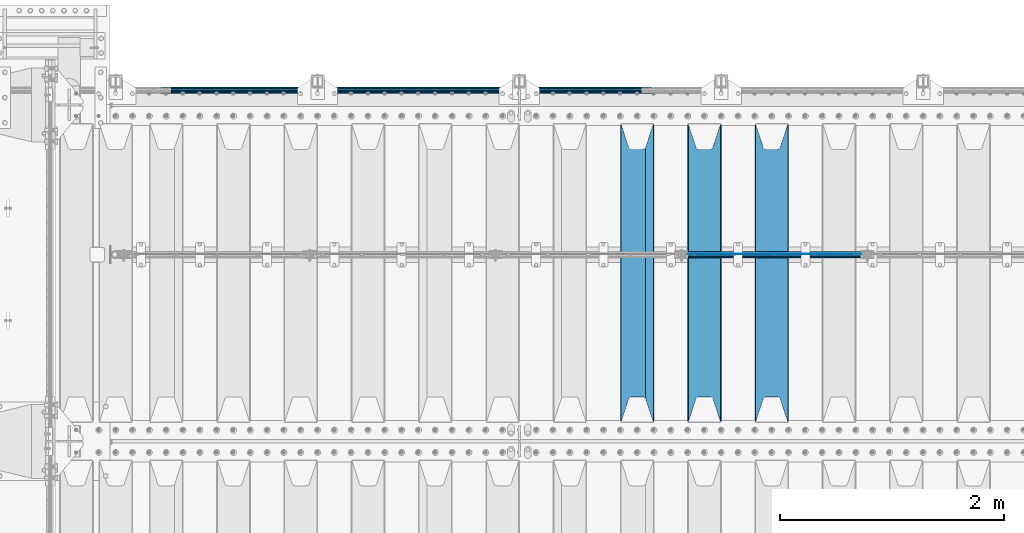
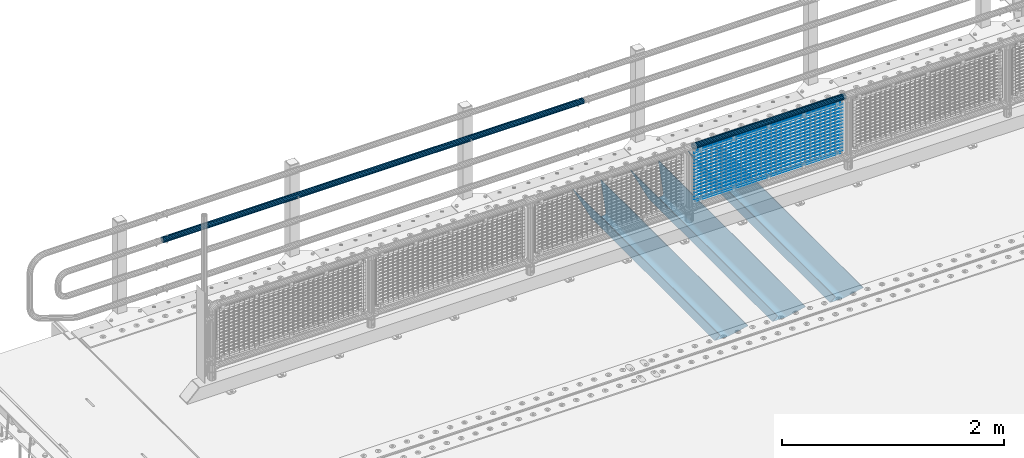
# One storey, part 112 of 219: 22 beams.
"""IFC2X3 building model written with IfcOpenShell, lengths in millimetres."""

from ifc_helpers import new_model, si_unit, frame, origin_with_axes, place, context, subcontext, project, spatial, faceted_brep, material, type_object, element, save


model = new_model("IFC2X3")

# Units and contexts
model_context = context("Model", 3, precision=1e-05, world=origin_with_axes())
body_context = subcontext(model_context, "Body", "Model", "MODEL_VIEW")
ifc_project = project(units=[si_unit("LENGTHUNIT", "METRE", prefix="MILLI"), si_unit("AREAUNIT", "SQUARE_METRE"), si_unit("VOLUMEUNIT", "CUBIC_METRE"), si_unit("MASSUNIT", "GRAM", prefix="KILO"), si_unit("TIMEUNIT", "SECOND"), si_unit("PLANEANGLEUNIT", "RADIAN"), si_unit("SOLIDANGLEUNIT", "STERADIAN"), si_unit("THERMODYNAMICTEMPERATUREUNIT", "DEGREE_CELSIUS"), si_unit("LUMINOUSINTENSITYUNIT", "LUMEN")], contexts=[model_context])

# Site, building, storey
site_placement = place(None, origin_with_axes())
site = spatial("IfcSite", under=ifc_project, at=site_placement, CompositionType="ELEMENT")
building_placement = place(site_placement, origin_with_axes())
building = spatial("IfcBuilding", under=site, at=building_placement, Name="Standard", CompositionType="ELEMENT")
storey_placement = place(building_placement, origin_with_axes())
storey = spatial("IfcBuildingStorey", under=building, at=storey_placement, Name="Undefined", CompositionType="ELEMENT", Elevation=0.0)

# Beams
ifc_material_1 = material(Name="STEEL/S355N")
beam_type_1 = type_object("IfcBeamType", PredefinedType="NOTDEFINED")
beam_1_placement = place(storey_placement, frame((6400.0, 30175.0, -115.0), z_axis=(0.0, 0.0, 1.0), x_axis=(0.0, 1.0, 0.0)))
element("IfcBeam", 1, at=beam_1_placement, inside=storey, type_object=beam_type_1, material=ifc_material_1, context=body_context, shape_type="Brep", body=[
    faceted_brep([(0.0, 150.0, 115.0), (0.0, 143.690000000001, 115.0), (2650.00000000297, 143.690000000001, 115.0), (2650.00000000297, 150.0, 115.0), (2650.00000000297, 142.0595652184, 110.000000003094), (2650.00000000297, 148.3695652184, 110.000000003094), (2441.90079219209, -80.110360073113, -98.0992078077845), (2437.7588105432, -77.5672621345566, -102.241189456673), (2434.06523489747, -74.4080125315541, -105.934765102404), (2430.9108609509, -70.7102721255742, -109.089139048974), (2428.37322971128, -66.5649389910068, -111.626770288588), (2426.51472138055, -62.0739139532889, -113.485278619323), (2425.38102192092, -57.3475956567672, -114.618978078955), (2424.99999999988, -52.5021667386536, -115.0), (2424.99999999988, 52.5021667386536, -115.0), (2425.38102192092, 57.3475956567672, -114.618978078955), (2426.51472138055, 62.0739139532889, -113.485278619323), (2428.37322971128, 66.5649389910068, -111.626770288588), (2430.9108609509, 70.7102721255742, -109.089139048974), (2434.06523489747, 74.4080125315541, -105.934765102404), (2437.7588105432, 77.5672621345566, -102.241189456673), (2441.90079219209, 80.110360073113, -98.0992078077846), (2446.38936140512, 81.9747917625791, -93.6106385947584), (2448.2494850041, 76.2713538057269, -91.7505149957729), (2444.62967112263, 74.7677798626082, -95.3703288772456), (2441.28936334127, 72.7168944282894, -98.710636658607), (2438.31067330439, 70.1691124903828, -101.689326695487), (2435.76682334748, 67.1870637758839, -104.233176652398), (2433.72034654134, 63.8440531834913, -106.279653458539), (2432.22154950042, 60.2222587982342, -107.778450499454), (2431.30727574265, 56.4107117849107, -108.692724257221), (2430.99999999987, 52.5031078186894, -109.0), (2430.99999999987, -52.5031078186894, -109.0), (2431.30727574265, -56.4107117849107, -108.692724257221), (2432.22154950042, -60.2222587982342, -107.778450499454), (2433.72034654134, -63.8440531834913, -106.279653458539), (2435.76682334748, -67.1870637758839, -104.233176652398), (2438.31067330439, -70.1691124903828, -101.689326695487), (2441.28936334127, -72.7168944282894, -98.7106366586071), (2444.62967112263, -74.7677798626082, -95.3703288772457), (2448.2494850041, -76.2713538057269, -91.7505149957729), (2650.00000000297, -142.0595652184, 110.000000003094), (2650.00000000297, -148.3695652184, 110.000000003094), (2446.38936140512, -81.9747917625791, -93.6106385947584), (2650.00000000297, -143.690000000001, 115.0), (2650.00000000297, -150.0, 115.0), (0.0, -143.690000000001, 115.0), (0.0, -150.0, 115.0), (0.0, -148.369565218261, 110.000000002667), (203.610638597427, -81.9747917625791, -93.6106385947584), (208.09920781045, -80.110360073113, -98.0992078077845), (212.241189459342, -77.5672621345566, -102.241189456673), (215.93476510507, -74.4080125315541, -105.934765102404), (219.089139051641, -70.7102721255742, -109.089139048974), (221.626770291256, -66.5649389910068, -111.626770288588), (223.485278621989, -62.0739139532889, -113.485278619323), (224.618978081624, -57.3475956567672, -114.618978078955), (225.000000002663, -52.5021667386536, -115.0), (225.000000002663, 52.5021667386536, -115.0), (224.618978081624, 57.3475956567672, -114.618978078955), (223.485278621989, 62.0739139532889, -113.485278619323), (221.626770291256, 66.5649389910068, -111.626770288588), (219.089139051641, 70.7102721255742, -109.089139048974), (215.93476510507, 74.4080125315541, -105.934765102404), (212.241189459342, 77.5672621345566, -102.241189456673), (208.09920781045, 80.110360073113, -98.0992078077846), (203.610638597427, 81.9747917625791, -93.6106385947584), (0.0, 148.369565218261, 110.000000002667), (0.0, 142.059565218262, 110.000000002667), (201.750514998439, 76.2713538057269, -91.7505149957729), (205.370328879915, 74.7677798626082, -95.3703288772456), (208.710636661275, 72.7168944282894, -98.710636658607), (211.689326698157, 70.1691124903828, -101.689326695487), (214.233176655063, 67.1870637758839, -104.233176652398), (216.279653461206, 63.8440531834913, -106.279653458539), (217.778450502123, 60.2222587982342, -107.778450499454), (218.69272425989, 56.4107117849107, -108.692724257221), (219.00000000267, 52.5031078186894, -109.0), (219.00000000267, -52.5031078186894, -109.0), (218.69272425989, -56.4107117849107, -108.692724257221), (217.778450502123, -60.2222587982342, -107.778450499454), (216.279653461206, -63.8440531834913, -106.279653458539), (214.233176655063, -67.1870637758839, -104.233176652398), (211.689326698157, -70.1691124903828, -101.689326695487), (208.710636661275, -72.7168944282894, -98.7106366586071), (205.370328879915, -74.7677798626082, -95.3703288772457), (201.750514998439, -76.2713538057269, -91.7505149957729), (0.0, -142.059565218262, 110.000000002667)], [[[0, 1, 2, 3]], [[3, 2, 4, 5]], [[6, 7, 8, 9, 10, 11, 12, 13, 14, 15, 16, 17, 18, 19, 20, 21, 22, 5, 4, 23, 24, 25, 26, 27, 28, 29, 30, 31, 32, 33, 34, 35, 36, 37, 38, 39, 40, 41, 42, 43]], [[44, 45, 42, 41]], [[46, 47, 45, 44]], [[43, 42, 45, 47, 48, 49]], [[6, 43, 49, 50]], [[7, 6, 50, 51]], [[8, 7, 51, 52]], [[9, 8, 52, 53]], [[10, 9, 53, 54]], [[11, 10, 54, 55]], [[12, 11, 55, 56]], [[13, 12, 56, 57]], [[14, 13, 57, 58]], [[15, 14, 58, 59]], [[16, 15, 59, 60]], [[17, 16, 60, 61]], [[18, 17, 61, 62]], [[19, 18, 62, 63]], [[20, 19, 63, 64]], [[21, 20, 64, 65]], [[22, 21, 65, 66]], [[0, 3, 5, 22, 66, 67]], [[1, 0, 67, 68]], [[23, 4, 2, 1, 68, 69]], [[24, 23, 69, 70]], [[25, 24, 70, 71]], [[26, 25, 71, 72]], [[27, 26, 72, 73]], [[28, 27, 73, 74]], [[29, 28, 74, 75]], [[30, 29, 75, 76]], [[31, 30, 76, 77]], [[32, 31, 77, 78]], [[33, 32, 78, 79]], [[34, 33, 79, 80]], [[35, 34, 80, 81]], [[36, 35, 81, 82]], [[37, 36, 82, 83]], [[38, 37, 83, 84]], [[39, 38, 84, 85]], [[40, 39, 85, 86]], [[46, 44, 41, 40, 86, 87]], [[47, 46, 87, 48]], [[86, 85, 84, 83, 82, 81, 80, 79, 78, 77, 76, 75, 74, 73, 72, 71, 70, 69, 68, 67, 66, 65, 64, 63, 62, 61, 60, 59, 58, 57, 56, 55, 54, 53, 52, 51, 50, 49, 48, 87]]]),
])
beam_2_placement = place(storey_placement, frame((5800.0, 30175.0, -115.0), z_axis=(0.0, 0.0, 1.0), x_axis=(0.0, 1.0, 0.0)))
element("IfcBeam", 2, at=beam_2_placement, inside=storey, type_object=beam_type_1, material=ifc_material_1, context=body_context, shape_type="Brep", body=[
    faceted_brep([(0.0, 150.0, 115.0), (0.0, 143.690000000001, 115.0), (2650.00000000297, 143.690000000001, 115.0), (2650.00000000297, 150.0, 115.0), (2650.00000000297, 142.0595652184, 110.000000003094), (2650.00000000297, 148.3695652184, 110.000000003094), (2441.90079219209, -80.110360073113, -98.0992078077845), (2437.7588105432, -77.5672621345566, -102.241189456673), (2434.06523489747, -74.4080125315541, -105.934765102404), (2430.9108609509, -70.7102721255742, -109.089139048974), (2428.37322971128, -66.5649389910068, -111.626770288588), (2426.51472138055, -62.0739139532889, -113.485278619323), (2425.38102192092, -57.3475956567672, -114.618978078955), (2424.99999999988, -52.5021667386536, -115.0), (2424.99999999988, 52.5021667386536, -115.0), (2425.38102192092, 57.3475956567672, -114.618978078955), (2426.51472138055, 62.0739139532889, -113.485278619323), (2428.37322971128, 66.5649389910068, -111.626770288588), (2430.9108609509, 70.7102721255742, -109.089139048974), (2434.06523489747, 74.4080125315541, -105.934765102404), (2437.7588105432, 77.5672621345566, -102.241189456673), (2441.90079219209, 80.110360073113, -98.0992078077846), (2446.38936140512, 81.9747917625791, -93.6106385947584), (2448.2494850041, 76.2713538057269, -91.7505149957729), (2444.62967112263, 74.7677798626082, -95.3703288772456), (2441.28936334127, 72.7168944282894, -98.710636658607), (2438.31067330439, 70.1691124903828, -101.689326695487), (2435.76682334748, 67.1870637758839, -104.233176652398), (2433.72034654134, 63.8440531834913, -106.279653458539), (2432.22154950042, 60.2222587982342, -107.778450499454), (2431.30727574265, 56.4107117849107, -108.692724257221), (2430.99999999987, 52.5031078186894, -109.0), (2430.99999999987, -52.5031078186894, -109.0), (2431.30727574265, -56.4107117849107, -108.692724257221), (2432.22154950042, -60.2222587982342, -107.778450499454), (2433.72034654134, -63.8440531834913, -106.279653458539), (2435.76682334748, -67.1870637758839, -104.233176652398), (2438.31067330439, -70.1691124903828, -101.689326695487), (2441.28936334127, -72.7168944282894, -98.7106366586071), (2444.62967112263, -74.7677798626082, -95.3703288772457), (2448.2494850041, -76.2713538057269, -91.7505149957729), (2650.00000000297, -142.0595652184, 110.000000003094), (2650.00000000297, -148.3695652184, 110.000000003094), (2446.38936140512, -81.9747917625791, -93.6106385947584), (2650.00000000297, -143.690000000001, 115.0), (2650.00000000297, -150.0, 115.0), (0.0, -143.690000000001, 115.0), (0.0, -150.0, 115.0), (0.0, -148.369565218261, 110.000000002667), (203.610638597427, -81.9747917625791, -93.6106385947584), (208.09920781045, -80.110360073113, -98.0992078077845), (212.241189459342, -77.5672621345566, -102.241189456673), (215.93476510507, -74.4080125315541, -105.934765102404), (219.089139051641, -70.7102721255742, -109.089139048974), (221.626770291256, -66.5649389910068, -111.626770288588), (223.485278621989, -62.0739139532889, -113.485278619323), (224.618978081624, -57.3475956567672, -114.618978078955), (225.000000002663, -52.5021667386536, -115.0), (225.000000002663, 52.5021667386536, -115.0), (224.618978081624, 57.3475956567672, -114.618978078955), (223.485278621989, 62.0739139532889, -113.485278619323), (221.626770291256, 66.5649389910068, -111.626770288588), (219.089139051641, 70.7102721255742, -109.089139048974), (215.93476510507, 74.4080125315541, -105.934765102404), (212.241189459342, 77.5672621345566, -102.241189456673), (208.09920781045, 80.110360073113, -98.0992078077846), (203.610638597427, 81.9747917625791, -93.6106385947584), (0.0, 148.369565218261, 110.000000002667), (0.0, 142.059565218262, 110.000000002667), (201.750514998439, 76.2713538057269, -91.7505149957729), (205.370328879915, 74.7677798626082, -95.3703288772456), (208.710636661275, 72.7168944282894, -98.710636658607), (211.689326698157, 70.1691124903828, -101.689326695487), (214.233176655063, 67.1870637758839, -104.233176652398), (216.279653461206, 63.8440531834913, -106.279653458539), (217.778450502123, 60.2222587982342, -107.778450499454), (218.69272425989, 56.4107117849107, -108.692724257221), (219.00000000267, 52.5031078186894, -109.0), (219.00000000267, -52.5031078186894, -109.0), (218.69272425989, -56.4107117849107, -108.692724257221), (217.778450502123, -60.2222587982342, -107.778450499454), (216.279653461206, -63.8440531834913, -106.279653458539), (214.233176655063, -67.1870637758839, -104.233176652398), (211.689326698157, -70.1691124903828, -101.689326695487), (208.710636661275, -72.7168944282894, -98.7106366586071), (205.370328879915, -74.7677798626082, -95.3703288772457), (201.750514998439, -76.2713538057269, -91.7505149957729), (0.0, -142.059565218262, 110.000000002667)], [[[0, 1, 2, 3]], [[3, 2, 4, 5]], [[6, 7, 8, 9, 10, 11, 12, 13, 14, 15, 16, 17, 18, 19, 20, 21, 22, 5, 4, 23, 24, 25, 26, 27, 28, 29, 30, 31, 32, 33, 34, 35, 36, 37, 38, 39, 40, 41, 42, 43]], [[44, 45, 42, 41]], [[46, 47, 45, 44]], [[43, 42, 45, 47, 48, 49]], [[6, 43, 49, 50]], [[7, 6, 50, 51]], [[8, 7, 51, 52]], [[9, 8, 52, 53]], [[10, 9, 53, 54]], [[11, 10, 54, 55]], [[12, 11, 55, 56]], [[13, 12, 56, 57]], [[14, 13, 57, 58]], [[15, 14, 58, 59]], [[16, 15, 59, 60]], [[17, 16, 60, 61]], [[18, 17, 61, 62]], [[19, 18, 62, 63]], [[20, 19, 63, 64]], [[21, 20, 64, 65]], [[22, 21, 65, 66]], [[0, 3, 5, 22, 66, 67]], [[1, 0, 67, 68]], [[23, 4, 2, 1, 68, 69]], [[24, 23, 69, 70]], [[25, 24, 70, 71]], [[26, 25, 71, 72]], [[27, 26, 72, 73]], [[28, 27, 73, 74]], [[29, 28, 74, 75]], [[30, 29, 75, 76]], [[31, 30, 76, 77]], [[32, 31, 77, 78]], [[33, 32, 78, 79]], [[34, 33, 79, 80]], [[35, 34, 80, 81]], [[36, 35, 81, 82]], [[37, 36, 82, 83]], [[38, 37, 83, 84]], [[39, 38, 84, 85]], [[40, 39, 85, 86]], [[46, 44, 41, 40, 86, 87]], [[47, 46, 87, 48]], [[86, 85, 84, 83, 82, 81, 80, 79, 78, 77, 76, 75, 74, 73, 72, 71, 70, 69, 68, 67, 66, 65, 64, 63, 62, 61, 60, 59, 58, 57, 56, 55, 54, 53, 52, 51, 50, 49, 48, 87]]]),
])
beam_3_placement = place(storey_placement, frame((5200.0, 30175.0, -115.0), z_axis=(0.0, 0.0, 1.0), x_axis=(0.0, 1.0, 0.0)))
element("IfcBeam", 3, at=beam_3_placement, inside=storey, type_object=beam_type_1, material=ifc_material_1, context=body_context, shape_type="Brep", body=[
    faceted_brep([(0.0, 150.0, 115.0), (0.0, 143.690000000001, 115.0), (2650.00000000297, 143.690000000001, 115.0), (2650.00000000297, 150.0, 115.0), (2650.00000000297, 142.0595652184, 110.000000003094), (2650.00000000297, 148.3695652184, 110.000000003094), (2441.90079219209, -80.110360073113, -98.0992078077845), (2437.7588105432, -77.5672621345566, -102.241189456673), (2434.06523489747, -74.4080125315541, -105.934765102404), (2430.9108609509, -70.7102721255742, -109.089139048974), (2428.37322971128, -66.5649389910068, -111.626770288588), (2426.51472138055, -62.0739139532889, -113.485278619323), (2425.38102192092, -57.3475956567672, -114.618978078955), (2424.99999999988, -52.5021667386536, -115.0), (2424.99999999988, 52.5021667386536, -115.0), (2425.38102192092, 57.3475956567672, -114.618978078955), (2426.51472138055, 62.0739139532889, -113.485278619323), (2428.37322971128, 66.5649389910068, -111.626770288588), (2430.9108609509, 70.7102721255742, -109.089139048974), (2434.06523489747, 74.4080125315541, -105.934765102404), (2437.7588105432, 77.5672621345566, -102.241189456673), (2441.90079219209, 80.110360073113, -98.0992078077846), (2446.38936140512, 81.9747917625791, -93.6106385947584), (2448.2494850041, 76.2713538057269, -91.7505149957729), (2444.62967112263, 74.7677798626082, -95.3703288772456), (2441.28936334127, 72.7168944282894, -98.710636658607), (2438.31067330439, 70.1691124903828, -101.689326695487), (2435.76682334748, 67.1870637758839, -104.233176652398), (2433.72034654134, 63.8440531834913, -106.279653458539), (2432.22154950042, 60.2222587982342, -107.778450499454), (2431.30727574265, 56.4107117849107, -108.692724257221), (2430.99999999987, 52.5031078186894, -109.0), (2430.99999999987, -52.5031078186894, -109.0), (2431.30727574265, -56.4107117849107, -108.692724257221), (2432.22154950042, -60.2222587982342, -107.778450499454), (2433.72034654134, -63.8440531834913, -106.279653458539), (2435.76682334748, -67.1870637758839, -104.233176652398), (2438.31067330439, -70.1691124903828, -101.689326695487), (2441.28936334127, -72.7168944282894, -98.7106366586071), (2444.62967112263, -74.7677798626082, -95.3703288772457), (2448.2494850041, -76.2713538057269, -91.7505149957729), (2650.00000000297, -142.0595652184, 110.000000003094), (2650.00000000297, -148.3695652184, 110.000000003094), (2446.38936140512, -81.9747917625791, -93.6106385947584), (2650.00000000297, -143.690000000001, 115.0), (2650.00000000297, -150.0, 115.0), (0.0, -143.690000000001, 115.0), (0.0, -150.0, 115.0), (0.0, -148.369565218261, 110.000000002667), (203.610638597427, -81.9747917625791, -93.6106385947584), (208.09920781045, -80.110360073113, -98.0992078077845), (212.241189459342, -77.5672621345566, -102.241189456673), (215.93476510507, -74.4080125315541, -105.934765102404), (219.089139051641, -70.7102721255742, -109.089139048974), (221.626770291256, -66.5649389910068, -111.626770288588), (223.485278621989, -62.0739139532889, -113.485278619323), (224.618978081624, -57.3475956567672, -114.618978078955), (225.000000002663, -52.5021667386536, -115.0), (225.000000002663, 52.5021667386536, -115.0), (224.618978081624, 57.3475956567672, -114.618978078955), (223.485278621989, 62.0739139532889, -113.485278619323), (221.626770291256, 66.5649389910068, -111.626770288588), (219.089139051641, 70.7102721255742, -109.089139048974), (215.93476510507, 74.4080125315541, -105.934765102404), (212.241189459342, 77.5672621345566, -102.241189456673), (208.09920781045, 80.110360073113, -98.0992078077846), (203.610638597427, 81.9747917625791, -93.6106385947584), (0.0, 148.369565218261, 110.000000002667), (0.0, 142.059565218262, 110.000000002667), (201.750514998439, 76.2713538057269, -91.7505149957729), (205.370328879915, 74.7677798626082, -95.3703288772456), (208.710636661275, 72.7168944282894, -98.710636658607), (211.689326698157, 70.1691124903828, -101.689326695487), (214.233176655063, 67.1870637758839, -104.233176652398), (216.279653461206, 63.8440531834913, -106.279653458539), (217.778450502123, 60.2222587982342, -107.778450499454), (218.69272425989, 56.4107117849107, -108.692724257221), (219.00000000267, 52.5031078186894, -109.0), (219.00000000267, -52.5031078186894, -109.0), (218.69272425989, -56.4107117849107, -108.692724257221), (217.778450502123, -60.2222587982342, -107.778450499454), (216.279653461206, -63.8440531834913, -106.279653458539), (214.233176655063, -67.1870637758839, -104.233176652398), (211.689326698157, -70.1691124903828, -101.689326695487), (208.710636661275, -72.7168944282894, -98.7106366586071), (205.370328879915, -74.7677798626082, -95.3703288772457), (201.750514998439, -76.2713538057269, -91.7505149957729), (0.0, -142.059565218262, 110.000000002667)], [[[0, 1, 2, 3]], [[3, 2, 4, 5]], [[6, 7, 8, 9, 10, 11, 12, 13, 14, 15, 16, 17, 18, 19, 20, 21, 22, 5, 4, 23, 24, 25, 26, 27, 28, 29, 30, 31, 32, 33, 34, 35, 36, 37, 38, 39, 40, 41, 42, 43]], [[44, 45, 42, 41]], [[46, 47, 45, 44]], [[43, 42, 45, 47, 48, 49]], [[6, 43, 49, 50]], [[7, 6, 50, 51]], [[8, 7, 51, 52]], [[9, 8, 52, 53]], [[10, 9, 53, 54]], [[11, 10, 54, 55]], [[12, 11, 55, 56]], [[13, 12, 56, 57]], [[14, 13, 57, 58]], [[15, 14, 58, 59]], [[16, 15, 59, 60]], [[17, 16, 60, 61]], [[18, 17, 61, 62]], [[19, 18, 62, 63]], [[20, 19, 63, 64]], [[21, 20, 64, 65]], [[22, 21, 65, 66]], [[0, 3, 5, 22, 66, 67]], [[1, 0, 67, 68]], [[23, 4, 2, 1, 68, 69]], [[24, 23, 69, 70]], [[25, 24, 70, 71]], [[26, 25, 71, 72]], [[27, 26, 72, 73]], [[28, 27, 73, 74]], [[29, 28, 74, 75]], [[30, 29, 75, 76]], [[31, 30, 76, 77]], [[32, 31, 77, 78]], [[33, 32, 78, 79]], [[34, 33, 79, 80]], [[35, 34, 80, 81]], [[36, 35, 81, 82]], [[37, 36, 82, 83]], [[38, 37, 83, 84]], [[39, 38, 84, 85]], [[40, 39, 85, 86]], [[46, 44, 41, 40, 86, 87]], [[47, 46, 87, 48]], [[86, 85, 84, 83, 82, 81, 80, 79, 78, 77, 76, 75, 74, 73, 72, 71, 70, 69, 68, 67, 66, 65, 64, 63, 62, 61, 60, 59, 58, 57, 56, 55, 54, 53, 52, 51, 50, 49, 48, 87]]]),
])
ifc_material_2 = material(Name="Misc_Undefined")
beam_type_2 = type_object("IfcBeamType", Name="D3", PredefinedType="NOTDEFINED")
for number, where, z_axis, x_axis in (
    (4, (5650.0, 31670.5, 851.597), (0.0, 0.0, 1.0), (1.0, 0.0, 0.0)),
    (5, (5650.0, 31670.5, 669.452), (0.0, 0.0, 1.0), (1.0, 0.0, 0.0)),
    (6, (5650.0, 31670.5, 523.736), (0.0, 0.0, 1.0), (1.0, 0.0, 0.0)),
    (7, (5650.0, 31670.5, 487.307), (0.0, 0.0, 1.0), (1.0, 0.0, 0.0)),
    (8, (5650.0, 31670.5, 705.881), (0.0, 0.0, 1.0), (1.0, 0.0, 0.0)),
    (9, (5650.0, 31670.5, 596.594000000001), (0.0, 0.0, 1.0), (1.0, 0.0, 0.0)),
    (10, (5650.0, 31670.5, 450.878), (0.0, 0.0, 1.0), (1.0, 0.0, 0.0)),
    (11, (5650.0, 31670.5, 815.168), (0.0, 0.0, 1.0), (1.0, 0.0, 0.0)),
    (12, (5650.0, 31670.5, 888.026), (0.0, 0.0, 1.0), (1.0, 0.0, 0.0)),
    (13, (5650.0, 31670.5, 778.739), (0.0, 0.0, 1.0), (1.0, 0.0, 0.0)),
    (14, (5650.0, 31670.5, 742.31), (0.0, 0.0, 1.0), (1.0, 0.0, 0.0)),
    (15, (5650.0, 31670.5, 633.023), (0.0, 0.0, 1.0), (1.0, 0.0, 0.0)),
    (16, (5650.0, 31670.5, 560.165), (0.0, 0.0, 1.0), (1.0, 0.0, 0.0)),
    (17, (5650.0, 31670.5, 414.449), (0.0, 0.0, 1.0), (1.0, 0.0, 0.0)),
):
    element("IfcBeam", number, at=place(storey_placement, frame(where, z_axis=z_axis, x_axis=x_axis)), inside=storey, type_object=beam_type_2, material=ifc_material_2, ObjectType="D3", context=body_context, shape_type="Brep", body=[
        faceted_brep([(0.0, -1.5, -5.6843418860808e-14), (0.0, -0.75, -1.29903810567669), (1548.0, -0.75, -1.29903810567669), (1548.0, -1.5, 0.0), (0.0, 0.75, -1.29903810567669), (1548.0, 0.75, -1.29903810567669), (0.0, 1.5, -5.6843418860808e-14), (1548.0, 1.5, 0.0), (0.0, 0.75, 1.29903810567669), (1548.0, 0.75, 1.29903810567669), (0.0, -0.75, 1.29903810567669), (1548.0, -0.75, 1.29903810567669)], [[[0, 1, 2, 3]], [[1, 4, 5, 2]], [[4, 6, 7, 5]], [[6, 8, 9, 7]], [[8, 10, 11, 9]], [[10, 0, 3, 11]], [[5, 7, 9, 11, 3, 2]], [[10, 8, 6, 4, 1, 0]]]),
    ])
beam_4_placement = place(storey_placement, frame((5675.0, 31670.5, 353.02), z_axis=(0.0, 0.0, 1.0), x_axis=(1.0, 0.0, 0.0)))
element("IfcBeam", 18, at=beam_4_placement, inside=storey, type_object=beam_type_2, material=ifc_material_2, ObjectType="D3", context=body_context, shape_type="Brep", body=[
    faceted_brep([(0.0, -1.5, -5.6843418860808e-14), (0.0, -0.75, -1.29903810567669), (1498.0, -0.75, -1.29903810567669), (1498.0, -1.5, 0.0), (0.0, 0.75, -1.29903810567669), (1498.0, 0.75, -1.29903810567663), (0.0, 1.5, -5.6843418860808e-14), (1498.0, 1.5, 0.0), (0.0, 0.75, 1.29903810567669), (1498.0, 0.75, 1.29903810567669), (0.0, -0.75, 1.29903810567669), (1498.0, -0.75, 1.29903810567669)], [[[0, 1, 2, 3]], [[1, 4, 5, 2]], [[4, 6, 7, 5]], [[6, 8, 9, 7]], [[8, 10, 11, 9]], [[10, 0, 3, 11]], [[5, 7, 9, 11, 3, 2]], [[10, 8, 6, 4, 1, 0]]]),
])
beam_5_placement = place(storey_placement, frame((5650.0, 31670.5, 378.02), z_axis=(0.0, 0.0, 1.0), x_axis=(1.0, 0.0, 0.0)))
element("IfcBeam", 19, at=beam_5_placement, inside=storey, type_object=beam_type_2, material=ifc_material_2, ObjectType="D3", context=body_context, shape_type="Brep", body=[
    faceted_brep([(0.0, -1.5, -5.6843418860808e-14), (0.0, -0.75, -1.29903810567669), (1548.0, -0.75, -1.29903810567669), (1548.0, -1.5, 0.0), (0.0, 0.75, -1.29903810567669), (1548.0, 0.75, -1.29903810567669), (0.0, 1.5, -5.6843418860808e-14), (1548.0, 1.5, 0.0), (0.0, 0.75, 1.29903810567669), (1548.0, 0.75, 1.29903810567669), (0.0, -0.75, 1.29903810567669), (1548.0, -0.75, 1.29903810567669)], [[[0, 1, 2, 3]], [[1, 4, 5, 2]], [[4, 6, 7, 5]], [[6, 8, 9, 7]], [[8, 10, 11, 9]], [[10, 0, 3, 11]], [[5, 7, 9, 11, 3, 2]], [[10, 8, 6, 4, 1, 0]]]),
])
beam_6_placement = place(storey_placement, frame((5675.0, 31670.5, 913.02), z_axis=(0.0, 0.0, 1.0), x_axis=(1.0, 0.0, 0.0)))
element("IfcBeam", 20, at=beam_6_placement, inside=storey, type_object=beam_type_2, material=ifc_material_2, ObjectType="D3", context=body_context, shape_type="Brep", body=[
    faceted_brep([(0.0, -1.5, -5.6843418860808e-14), (0.0, -0.75, -1.29903810567669), (1498.0, -0.75, -1.29903810567669), (1498.0, -1.5, 0.0), (0.0, 0.75, -1.29903810567669), (1498.0, 0.75, -1.29903810567663), (0.0, 1.5, -5.6843418860808e-14), (1498.0, 1.5, 0.0), (0.0, 0.75, 1.29903810567669), (1498.0, 0.75, 1.29903810567669), (0.0, -0.75, 1.29903810567669), (1498.0, -0.75, 1.29903810567669)], [[[0, 1, 2, 3]], [[1, 4, 5, 2]], [[4, 6, 7, 5]], [[6, 8, 9, 7]], [[8, 10, 11, 9]], [[10, 0, 3, 11]], [[5, 7, 9, 11, 3, 2]], [[10, 8, 6, 4, 1, 0]]]),
])
ifc_material_3 = material()
beam_type_3 = type_object("IfcBeamType", PredefinedType="NOTDEFINED")
beam_7_placement = place(storey_placement, frame((5629.85, 31664.5, 969.85), z_axis=(0.0, 0.0, 1.0), x_axis=(1.0, 0.0, 0.0)))
element("IfcBeam", 21, at=beam_7_placement, inside=storey, type_object=beam_type_3, material=ifc_material_3, context=body_context, shape_type="Brep", body=[
    faceted_brep([(0.0, -25.3499999999985, 0.0), (0.0, -23.4203461491597, 9.70102501045585), (1588.0, -23.4203461491597, 9.70102501045506), (1588.0, -25.3499999999985, 0.0), (0.0, -17.9251569030785, 17.9251569030785), (1588.0, -17.9251569030785, 17.925156903079), (0.0, -9.70102501045403, 23.4203461491616), (1588.0, -9.70102501045403, 23.4203461491611), (0.0, 0.0, 25.3500000000004), (1588.0, 0.0, 25.35), (0.0, 9.70102501045403, 23.4203461491616), (1588.0, 9.70102501045403, 23.4203461491611), (0.0, 17.9251569030785, 17.9251569030785), (1588.0, 17.9251569030785, 17.925156903079), (0.0, 23.4203461491597, 9.70102501045585), (1588.0, 23.4203461491597, 9.70102501045506), (0.0, 25.3499999999985, 0.0), (1588.0, 25.3499999999985, 0.0), (0.0, 23.4203461491597, -9.70102501045585), (1588.0, 23.4203461491597, -9.70102501045506), (0.0, 17.9251569030785, -17.9251569030785), (1588.0, 17.9251569030785, -17.925156903079), (0.0, 9.70102501045403, -23.4203461491616), (1588.0, 9.70102501045403, -23.4203461491611), (0.0, 0.0, -25.3500000000004), (1588.0, 0.0, -25.35), (0.0, -9.70102501045403, -23.4203461491616), (1588.0, -9.70102501045403, -23.4203461491611), (0.0, -17.9251569030785, -17.9251569030785), (1588.0, -17.9251569030785, -17.925156903079), (0.0, -23.4203461491597, -9.70102501045585), (1588.0, -23.4203461491597, -9.70102501045506), (0.0, -30.1500000000015, 0.0), (0.0, -27.8549679052157, -11.5379054858076), (1588.0, -27.8549679052157, -11.5379054858075), (1588.0, -30.1500000000015, 0.0), (0.0, -21.3192694527752, -21.3192694527752), (1588.0, -21.3192694527752, -21.3192694527744), (0.0, -11.5379054858058, -27.8549679052157), (1588.0, -11.5379054858058, -27.8549679052153), (0.0, 0.0, -30.1499999999996), (1588.0, 0.0, -30.15), (0.0, 11.5379054858058, -27.8549679052157), (1588.0, 11.5379054858058, -27.8549679052153), (0.0, 21.3192694527752, -21.3192694527752), (1588.0, 21.3192694527752, -21.3192694527744), (0.0, 27.8549679052157, -11.5379054858076), (1588.0, 27.8549679052157, -11.5379054858074), (0.0, 30.1500000000015, 0.0), (1588.0, 30.1500000000015, 0.0), (0.0, 27.8549679052157, 11.5379054858076), (1588.0, 27.8549679052157, 11.5379054858074), (0.0, 21.3192694527752, 21.3192694527752), (1588.0, 21.3192694527752, 21.3192694527744), (0.0, 11.5379054858058, 27.8549679052157), (1588.0, 11.5379054858058, 27.8549679052153), (0.0, 0.0, 30.1499999999996), (1588.0, 0.0, 30.15), (0.0, -11.5379054858058, 27.8549679052157), (1588.0, -11.5379054858058, 27.8549679052153), (0.0, -21.3192694527752, 21.3192694527752), (1588.0, -21.3192694527752, 21.3192694527744), (0.0, -27.8549679052157, 11.5379054858076), (1588.0, -27.8549679052157, 11.5379054858074)], [[[0, 1, 2, 3]], [[1, 4, 5, 2]], [[4, 6, 7, 5]], [[6, 8, 9, 7]], [[8, 10, 11, 9]], [[10, 12, 13, 11]], [[12, 14, 15, 13]], [[14, 16, 17, 15]], [[16, 18, 19, 17]], [[18, 20, 21, 19]], [[20, 22, 23, 21]], [[22, 24, 25, 23]], [[24, 26, 27, 25]], [[26, 28, 29, 27]], [[28, 30, 31, 29]], [[30, 0, 3, 31]], [[32, 33, 34, 35]], [[33, 36, 37, 34]], [[36, 38, 39, 37]], [[38, 40, 41, 39]], [[40, 42, 43, 41]], [[42, 44, 45, 43]], [[44, 46, 47, 45]], [[46, 48, 49, 47]], [[48, 50, 51, 49]], [[50, 52, 53, 51]], [[52, 54, 55, 53]], [[54, 56, 57, 55]], [[56, 58, 59, 57]], [[58, 60, 61, 59]], [[60, 62, 63, 61]], [[62, 32, 35, 63]], [[37, 39, 41, 43, 45, 47, 49, 51, 53, 55, 57, 59, 61, 63, 35, 34], [5, 7, 9, 11, 13, 15, 17, 19, 21, 23, 25, 27, 29, 31, 3, 2]], [[62, 60, 58, 56, 54, 52, 50, 48, 46, 44, 42, 40, 38, 36, 33, 32], [30, 28, 26, 24, 22, 20, 18, 16, 14, 12, 10, 8, 6, 4, 1, 0]]]),
])
beam_type_4 = type_object("IfcBeamType", PredefinedType="NOTDEFINED")
beam_8_placement = place(storey_placement, frame((5333.99999999987, 33129.8500000001, 689.849999999748), z_axis=(0.0, 0.0, -1.0), x_axis=(-1.0, 0.0, 0.0)))
element("IfcBeam", 22, at=beam_8_placement, inside=storey, type_object=beam_type_4, material=ifc_material_3, context=body_context, shape_type="Brep", body=[
    faceted_brep([(0.0, -26.5500000000029, 0.0), (0.0, -24.5290015881765, 10.1602451292931), (4384.00249699992, -24.5290015881765, 10.1602451292931), (4384.00249699992, -26.5500000000029, 0.0), (0.0, -18.7736850405054, 18.7736850405028), (4384.00249699992, -18.7736850405054, 18.7736850405028), (0.0, -10.1602451292929, 24.5290015881747), (4384.00249699992, -10.1602451292929, 24.5290015881747), (0.0, 0.0, 26.55), (4384.00249699992, 0.0, 26.55), (0.0, 10.1602451292929, 24.5290015881747), (4384.00249699992, 10.1602451292929, 24.5290015881747), (0.0, 18.7736850405054, 18.7736850405028), (4384.00249699992, 18.7736850405054, 18.7736850405028), (0.0, 24.5290015881765, 10.1602451292931), (4384.00249699992, 24.5290015881765, 10.1602451292931), (0.0, 26.5500000000029, 0.0), (4384.00249699992, 26.5500000000029, 0.0), (0.0, 24.5290015881765, -10.1602451292931), (4384.00249699992, 24.5290015881765, -10.1602451292931), (0.0, 18.7736850405054, -18.7736850405028), (4384.00249699992, 18.7736850405054, -18.7736850405028), (0.0, 10.1602451292929, -24.5290015881747), (4384.00249699992, 10.1602451292929, -24.5290015881747), (0.0, 0.0, -26.55), (4384.00249699992, 0.0, -26.55), (0.0, -10.1602451292929, -24.5290015881747), (4384.00249699992, -10.1602451292929, -24.5290015881747), (0.0, -18.7736850405054, -18.7736850405028), (4384.00249699992, -18.7736850405054, -18.7736850405028), (0.0, -24.5290015881765, -10.1602451292931), (4384.00249699992, -24.5290015881765, -10.1602451292931), (0.0, -30.1500000000015, 0.0), (0.0, -27.8549679052157, -11.5379054858076), (4384.00249699992, -27.8549679052157, -11.5379054858075), (4384.00249699992, -30.1500000000015, 0.0), (0.0, -21.3192694527752, -21.3192694527752), (4384.00249699992, -21.3192694527752, -21.3192694527744), (0.0, -11.5379054858058, -27.8549679052157), (4384.00249699992, -11.5379054858058, -27.8549679052153), (0.0, 0.0, -30.1499999999996), (4384.00249699992, 0.0, -30.15), (0.0, 11.5379054858058, -27.8549679052157), (4384.00249699992, 11.5379054858058, -27.8549679052153), (0.0, 21.3192694527752, -21.3192694527752), (4384.00249699992, 21.3192694527752, -21.3192694527744), (0.0, 27.8549679052157, -11.5379054858076), (4384.00249699992, 27.8549679052157, -11.5379054858074), (0.0, 30.1500000000015, 0.0), (4384.00249699992, 30.1500000000015, 0.0), (0.0, 27.8549679052157, 11.5379054858076), (4384.00249699992, 27.8549679052157, 11.5379054858075), (0.0, 21.3192694527752, 21.3192694527752), (4384.00249699992, 21.3192694527752, 21.3192694527744), (0.0, 11.5379054858058, 27.8549679052157), (4384.00249699992, 11.5379054858058, 27.8549679052153), (0.0, 0.0, 30.1499999999996), (4384.00249699992, 0.0, 30.15), (0.0, -11.5379054858058, 27.8549679052157), (4384.00249699992, -11.5379054858058, 27.8549679052153), (0.0, -21.3192694527752, 21.3192694527752), (4384.00249699992, -21.3192694527752, 21.3192694527744), (0.0, -27.8549679052157, 11.5379054858076), (4384.00249699992, -27.8549679052157, 11.5379054858075)], [[[0, 1, 2, 3]], [[1, 4, 5, 2]], [[4, 6, 7, 5]], [[6, 8, 9, 7]], [[8, 10, 11, 9]], [[10, 12, 13, 11]], [[12, 14, 15, 13]], [[14, 16, 17, 15]], [[16, 18, 19, 17]], [[18, 20, 21, 19]], [[20, 22, 23, 21]], [[22, 24, 25, 23]], [[24, 26, 27, 25]], [[26, 28, 29, 27]], [[28, 30, 31, 29]], [[30, 0, 3, 31]], [[32, 33, 34, 35]], [[33, 36, 37, 34]], [[36, 38, 39, 37]], [[38, 40, 41, 39]], [[40, 42, 43, 41]], [[42, 44, 45, 43]], [[44, 46, 47, 45]], [[46, 48, 49, 47]], [[48, 50, 51, 49]], [[50, 52, 53, 51]], [[52, 54, 55, 53]], [[54, 56, 57, 55]], [[56, 58, 59, 57]], [[58, 60, 61, 59]], [[60, 62, 63, 61]], [[62, 32, 35, 63]], [[37, 39, 41, 43, 45, 47, 49, 51, 53, 55, 57, 59, 61, 63, 35, 34], [5, 7, 9, 11, 13, 15, 17, 19, 21, 23, 25, 27, 29, 31, 3, 2]], [[62, 60, 58, 56, 54, 52, 50, 48, 46, 44, 42, 40, 38, 36, 33, 32], [30, 28, 26, 24, 22, 20, 18, 16, 14, 12, 10, 8, 6, 4, 1, 0]]]),
])

save(model, "model.ifc")
